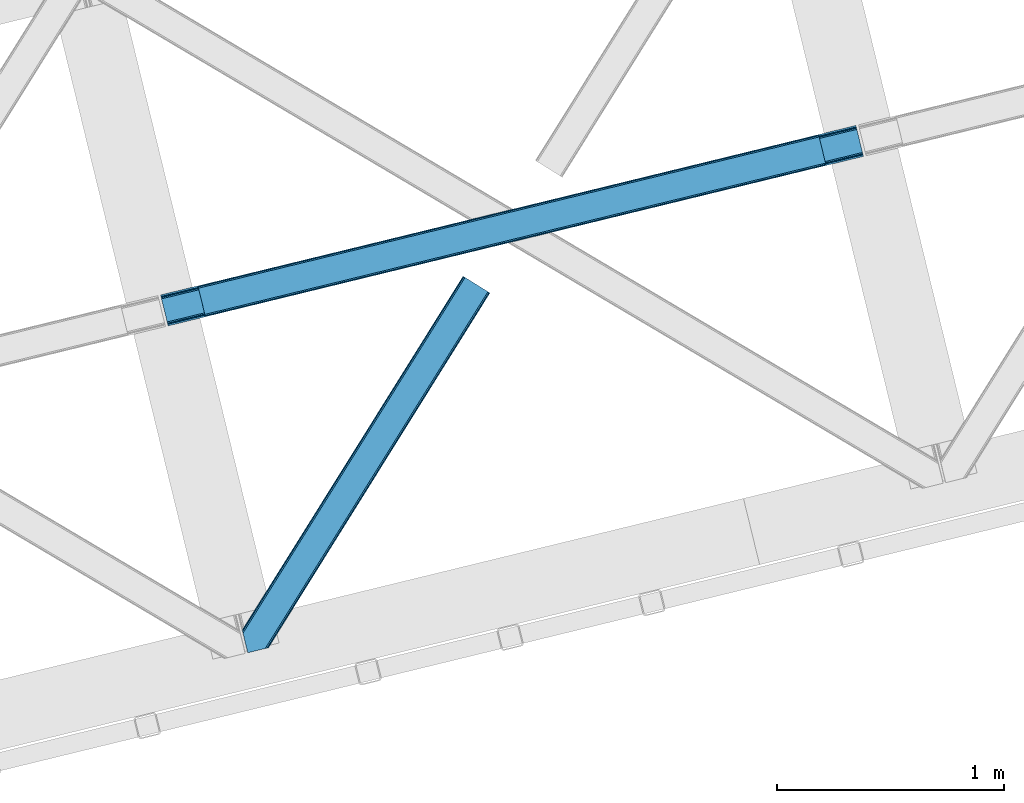
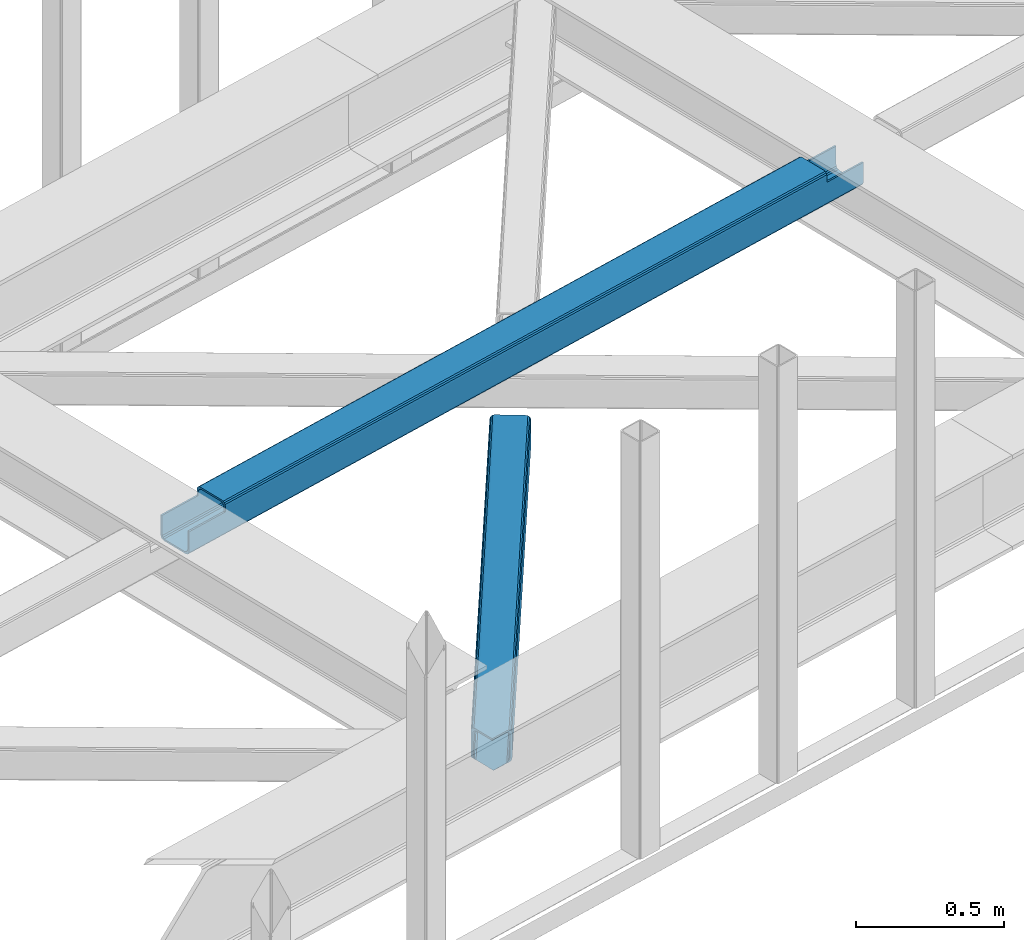
# One storey, part 42 of 67: 1 beam, 1 member.
"""IFC4 building model written with IfcOpenShell, lengths in millimetres."""

from ifc_helpers import new_model, entity, si_unit, converted_unit, derived_unit, direction, frame, origin, place, context, subcontext, project, spatial, triangles, polygons, material, type_object, element, save


model = new_model("IFC4")

# Units and contexts
model_context = context("Model", 3, precision=0.01, world=origin(), true_north=direction((6.12303176911189e-17, 1.0)))
plan_context = context("Plan", 3, precision=0.01, world=origin(), true_north=direction((6.12303176911189e-17, 1.0)))
body_context = subcontext(model_context, "Body", "Model", "MODEL_VIEW")
ifc_project = project(units=[si_unit("LENGTHUNIT", "METRE", prefix="MILLI"), si_unit("AREAUNIT", "SQUARE_METRE"), si_unit("VOLUMEUNIT", "CUBIC_METRE"), converted_unit("PLANEANGLEUNIT", "DEGREE", entity("IfcRatioMeasure", 0.0174532925199433), si_unit("PLANEANGLEUNIT", "RADIAN"), dimensions=[0, 0, 0, 0, 0, 0, 0]), si_unit("MASSUNIT", "GRAM", prefix="KILO"), derived_unit("MASSDENSITYUNIT", [(si_unit("MASSUNIT", "GRAM", prefix="KILO"), 1), (si_unit("LENGTHUNIT", "METRE"), -3)]), derived_unit("MOMENTOFINERTIAUNIT", [(si_unit("LENGTHUNIT", "METRE"), 4)]), si_unit("TIMEUNIT", "SECOND"), si_unit("FREQUENCYUNIT", "HERTZ"), si_unit("THERMODYNAMICTEMPERATUREUNIT", "DEGREE_CELSIUS"), derived_unit("THERMALTRANSMITTANCEUNIT", [(si_unit("MASSUNIT", "GRAM", prefix="KILO"), 1), (si_unit("THERMODYNAMICTEMPERATUREUNIT", "KELVIN"), -1), (si_unit("TIMEUNIT", "SECOND"), -3)]), derived_unit("VOLUMETRICFLOWRATEUNIT", [(si_unit("LENGTHUNIT", "METRE"), 3), (si_unit("TIMEUNIT", "SECOND"), -1)]), derived_unit("MASSFLOWRATEUNIT", [(si_unit("MASSUNIT", "GRAM", prefix="KILO"), 1), (si_unit("TIMEUNIT", "SECOND"), -1)]), derived_unit("ROTATIONALFREQUENCYUNIT", [(si_unit("TIMEUNIT", "SECOND"), -1)]), si_unit("ELECTRICCURRENTUNIT", "AMPERE"), si_unit("ELECTRICVOLTAGEUNIT", "VOLT"), si_unit("POWERUNIT", "WATT"), si_unit("FORCEUNIT", "NEWTON", prefix="KILO"), si_unit("ILLUMINANCEUNIT", "LUX"), si_unit("LUMINOUSFLUXUNIT", "LUMEN"), si_unit("LUMINOUSINTENSITYUNIT", "CANDELA"), derived_unit("USERDEFINED", [(si_unit("MASSUNIT", "GRAM", prefix="KILO"), -1), (si_unit("LENGTHUNIT", "METRE"), -2), (si_unit("TIMEUNIT", "SECOND"), 3), (si_unit("LUMINOUSFLUXUNIT", "LUMEN"), 1)]), derived_unit("LINEARVELOCITYUNIT", [(si_unit("LENGTHUNIT", "METRE"), 1), (si_unit("TIMEUNIT", "SECOND"), -1)]), si_unit("PRESSUREUNIT", "PASCAL"), derived_unit("USERDEFINED", [(si_unit("LENGTHUNIT", "METRE"), -2), (si_unit("MASSUNIT", "GRAM", prefix="KILO"), 1), (si_unit("TIMEUNIT", "SECOND"), -2)]), derived_unit("LINEARFORCEUNIT", [(si_unit("MASSUNIT", "GRAM", prefix="KILO"), 1), (si_unit("LENGTHUNIT", "METRE"), 1), (si_unit("TIMEUNIT", "SECOND"), -2), (si_unit("LENGTHUNIT", "METRE"), -1)]), derived_unit("PLANARFORCEUNIT", [(si_unit("MASSUNIT", "GRAM", prefix="KILO"), 1), (si_unit("LENGTHUNIT", "METRE"), 1), (si_unit("TIMEUNIT", "SECOND"), -2), (si_unit("LENGTHUNIT", "METRE"), -2)])], contexts=[model_context, plan_context])

# Site, building, storey
site_placement = place(None, origin())
site = spatial("IfcSite", under=ifc_project, at=site_placement, CompositionType="ELEMENT")
building_placement = place(site_placement, origin())
building = spatial("IfcBuilding", under=site, at=building_placement, CompositionType="ELEMENT")
storey_placement = place(building_placement, frame((0.0, 0.0, 19800.0)))
storey = spatial("IfcBuildingStorey", under=building, at=storey_placement, CompositionType="ELEMENT", Elevation=19800.0)

# Beam
ifc_material = material(Name="Metal painted (White)")
beam_type = type_object("IfcBeamType", PredefinedType="BEAM")
beam_placement = place(storey_placement, frame((-23668.0844907554, 13370.596470342, 3967.02022389142)))
element("IfcBeam", 1, at=beam_placement, inside=storey, type_object=beam_type, material=ifc_material, ObjectType="Steel Beam", PredefinedType="BEAM", context=body_context, shape_type="Tessellation", body=[
    polygons([(31.1823923917571, 8.09507685196108, 17.8030399336114), (31.4978703677187, 6.80086440699217, 24.4999999999988), (3089.94374939707, 752.329405140572, 24.4999999999988), (3089.62827142112, 753.623617585543, 17.8030399336114), (30.2839871259035, 11.7806820741864, 12.1256313292298), (3088.72986615527, 757.309222807771, 12.1256313292298), (28.9394286278234, 17.2965800886753, 8.33210818105214), (3087.38530765718, 762.82512082226, 8.33210818105214), (27.3534137403861, 23.8030254244683, 7.00000000000274), (3085.79929276975, 769.331566158049, 7.00000000000274), (4.21622439082827, 118.720708051134, 8.33210818105214), (5.80223927826556, 112.214262715343, 7.00000000000274), (3064.24811830762, 857.742803448927, 7.00000000000274), (3062.66210342019, 864.249248784716, 8.33210818105214), (2.87166589274824, 124.236606065622, 12.1256313292342), (3061.31754492211, 869.765146799203, 12.1256313292342), (1.9732606268946, 127.922211287848, 17.8030399336114), (3060.41913965625, 873.450752021432, 17.8030399336114), (1.65778265093735, 129.216423732819, 24.4999999999988), (3060.10366168028, 874.744964466397, 24.4999999999988), (33.1556530186517, 2.16573425859679e-12, 17.5000000000004), (33.155653018656, 2.16573425859679e-12, 99.499999999999), (31.4978703677273, 6.80086440699434, 99.499999999999), (1.65778265094168, 129.216423732819, 99.499999999999), (1.29944055515807e-11, 136.017288139811, 99.499999999999), (8.66293703438714e-12, 136.017288139811, 17.5000000000004), (0.315477975970248, 134.72307569484, 10.803039933613), (1.21388324181955, 131.037470472615, 5.12563132923143), (2.55844173990391, 125.521572458126, 1.33210818105373), (4.14445662733688, 119.015127122335, 0.0), (29.0111963913235, 17.0021610174783, 0.0), (30.5972112787608, 10.4957156816875, 1.33210818105373), (31.9417697768408, 4.97981766719851, 5.12563132923576), (32.8401750426944, 1.29421244497107, 10.803039933613), (3058.44587902935, 881.545828873387, 17.5000000000004), (3058.44587902935, 881.545828873387, 99.499999999999), (3060.10366168027, 874.744964466395, 99.499999999999), (3089.94374939706, 752.32940514057, 99.499999999999), (3091.60153204799, 745.52854073358, 99.499999999999), (3091.60153204799, 745.52854073358, 17.5000000000004), (3091.28605407204, 746.822753178549, 10.803039933613), (3090.38764880618, 750.508358400772, 5.12563132923576), (3089.0430903081, 756.024256415263, 1.33210818105373), (3087.45707542067, 762.530701751056, 0.0), (3062.59033565668, 864.543667855911, 0.0), (3061.00432076925, 871.050113191702, 1.33210818105373), (3059.65976227116, 876.566011206191, 5.12563132923143), (3058.76135700531, 880.251616428418, 10.803039933613), (2925.75994180944, 712.307865540887, 115.5000123926), (2925.8163098943, 712.321604759503, 100.117303289864), (2926.72300362931, 712.542621518197, 99.499999999999), (194.718606580809, 46.58768115868, 99.5063429816656), (195.631369831921, 46.8101414945073, 100.117301735448), (195.690168193635, 46.8244741223611, 115.5), (2928.38078628024, 705.741757111205, 99.499999999999), (2927.47422618799, 705.520772937698, 100.117303484932), (2927.41464342032, 705.506249905356, 122.500007895425), (197.345360928056, 40.0229783796067, 122.500002534479), (197.338587096745, 40.0213271441479, 100.500009163303), (196.748205195729, 39.8773799905087, 99.5697919021647), (2896.88292546721, 834.958147714716, 99.5063429816656), (2895.97381660775, 834.736577552001, 100.117299778624), (2895.91744852288, 834.722838333383, 115.50000888136), (165.85008047685, 169.240033448183, 115.5), (165.840462203347, 169.237688832044, 100.50000941238), (165.250325295037, 169.093836777333, 99.5761204674868), (2894.8533268523, 841.668448882887, 99.5697919021647), (163.220745767778, 175.804071762186, 99.499999999999), (164.133244938523, 176.026503182401, 100.117301984524), (164.189439987641, 176.04020120897, 122.500002796667), (2894.25631754638, 841.522886341466, 122.500003994045), (2894.2664208352, 841.525349756033, 100.500018741102), (2894.56843170076, 840.227853719303, 129.196959150505), (2895.46176722634, 836.541012377608, 134.874360354937), (2896.80305823041, 831.024317672804, 138.667878733795), (2898.38810531641, 824.517636364728, 139.999985502214), (2923.25885436335, 722.505647815416, 139.999991354283), (2924.84634848093, 715.999563150013, 138.667885332354), (2926.19460804137, 710.484567539782, 134.874367586349), (2927.09837274858, 706.800269072832, 129.196966804773), (2925.44675217774, 713.602635936904, 122.196975799125), (2924.54298747052, 717.286934403861, 127.874376580702), (2923.19472791009, 722.801930014085, 131.667894326702), (2921.6072337925, 729.30801467949, 133.000000348631), (2900.0525846185, 817.718404755559, 132.999995276841), (2898.46753753249, 824.225086063634, 131.667888508414), (2897.12624652842, 829.741780768443, 127.874370129564), (2896.23291100283, 833.428622110133, 122.196968925133), (164.878528418711, 169.003207355196, 99.499999999999), (193.13172645374, 57.3201898040421, 131.667891818946), (191.545711566303, 63.8266351398372, 133.0), (194.476284951825, 51.8042917895531, 127.874368670764), (195.374690217678, 48.11868656733, 122.196960066391), (169.994537104182, 152.237872430714, 133.0), (166.165558452811, 167.945821003219, 122.196960066391), (167.063963718665, 164.260215780994, 127.874368670764), (168.408522216745, 158.744317766505, 131.667891818946), (197.031411944082, 41.3175635421181, 129.196961104604), (196.136488323074, 45.0040174739024, 134.874366301861), (194.794244157323, 50.5204796458751, 138.667887185257), (193.209023953591, 57.0271186992037, 139.999994588639), (168.341882306945, 159.039986838394, 139.999994981919), (166.755021471193, 165.546225960036, 138.667887628704), (165.408105180739, 171.061549222932, 134.874366787843), (164.506189230969, 174.746298656828, 129.196961619)], [[[1, 2, 3, 4]], [[5, 1, 4, 6]], [[7, 5, 6, 8]], [[9, 7, 8, 10]], [[11, 12, 13, 14]], [[15, 11, 14, 16]], [[17, 15, 16, 18]], [[19, 17, 18, 20]], [[12, 9, 10, 13]], [[21, 22, 23, 2, 1, 5, 7, 9, 12, 11, 15, 17, 19, 24, 25, 26, 27, 28, 29, 30, 31, 32, 33, 34]], [[35, 36, 37, 20, 18, 16, 14, 13, 10, 8, 6, 4, 3, 38, 39, 40, 41, 42, 43, 44, 45, 46, 47, 48]], [[49, 50, 51, 38, 3, 2, 23, 52, 53, 54]], [[55, 39, 38, 51]], [[39, 55, 56, 57, 58, 59, 60, 22, 21, 40]], [[32, 31, 44, 43]], [[33, 32, 43, 42]], [[34, 33, 42, 41]], [[21, 34, 41, 40]], [[31, 30, 45, 44]], [[27, 26, 35, 48]], [[28, 27, 48, 47]], [[29, 28, 47, 46]], [[30, 29, 46, 45]], [[20, 37, 61, 62, 63, 64, 65, 66, 24, 19]], [[67, 36, 35, 26, 25, 68, 69, 70, 71, 72]], [[36, 67, 61, 37]], [[72, 71, 73, 74, 75, 76, 77, 78, 79, 80, 57, 56, 50, 49, 81, 82, 83, 84, 85, 86, 87, 88, 63, 62]], [[60, 52, 23, 22]], [[25, 24, 89, 68]], [[90, 91, 84, 83]], [[92, 90, 83, 82]], [[93, 92, 82, 81]], [[54, 93, 81, 49]], [[94, 85, 84, 91]], [[95, 64, 63, 88]], [[96, 95, 88, 87]], [[97, 96, 87, 86]], [[94, 97, 86, 85]], [[65, 64, 95, 96, 97, 94, 91, 90, 92, 93, 54, 53, 59, 58, 98, 99, 100, 101, 102, 103, 104, 105, 70, 69]], [[98, 58, 57, 80]], [[99, 98, 80, 79]], [[100, 99, 79, 78]], [[101, 100, 78, 77]], [[77, 76, 102, 101]], [[103, 102, 76, 75]], [[104, 103, 75, 74]], [[105, 104, 74, 73]], [[70, 105, 73, 71]]], closed=False),
])

# Member
member_type = type_object("IfcMemberType", PredefinedType="BRACE")
member_placement = place(storey_placement, frame((-23308.988873291, 11932.6995483398, 3822.99993896484)))
element("IfcMember", 2, at=member_placement, inside=storey, type_object=member_type, ObjectType="Steel Horizontal Brace", PredefinedType="BRACE", context=body_context, shape_type="Tessellation", body=[
    triangles([(986.153759765624, 1647.42967529297, 0.0), (1075.22274169922, 1591.82725524902, 0.0), (119.790362548825, 259.603921508789, 0.0), (154.551031494138, 117.003323364257, 0.0), (115.904553222656, 275.544808959961, 4.52065429687718), (117.571893310545, 268.698715209961, 1.33247680664135), (158.436840820312, 101.062435913085, 4.52065429687718), (156.767175292967, 107.908529663086, 1.33247680664135), (114.825549316403, 275.742471313477, 5.52059326172093), (115.132507324219, 275.92385559082, 5.35316162109302), (158.132208251951, 99.1218566894531, 5.27642211914281), (115.441790771481, 276.107565307617, 5.18107910156323), (158.234527587891, 99.7776306152336, 5.02062377929906), (158.190344238279, 99.4822998046875, 5.13457031250073), (115.544110107421, 276.168026733398, 5.12526855468968), (115.68596191406, 275.921530151367, 4.88574829101708), (158.336846923827, 100.433404541016, 4.76482543945531), (158.032214355466, 98.4928253173821, 5.52059326172093), (1085.71977539062, 1585.27416687012, 5.12526855468968), (1080.9037902832, 1588.28096008301, 1.33247680664135), (1088.93818359375, 1583.26498718262, 10.8039916992202), (114.21163330078, 21.8533172607422, 10.8039916992202), (109.467736816405, 20.6964111328125, 5.52059326172093), (1090.06834716797, 1582.55921630859, 17.5012573242202), (116.062683105469, 22.3044525146488, 17.5012573242202), (6.75307617187354, 102.619317626953, 5.52059326172093), (31.3655273437471, 1.65803833007885, 5.52059326172093), (1090.06834716797, 1582.55921630859, 122.499499511719), (116.062683105469, 22.3044525146488, 122.499499511719), (1088.93818359375, 1583.26498718262, 129.196765136719), (114.21163330078, 21.8533172607422, 129.196765136719), (1085.71977539062, 1585.27416687012, 134.87548828125), (108.937536621092, 20.5673492431633, 134.87548828125), (1080.9037902832, 1588.28096008301, 138.668280029298), (101.042669677732, 18.6430480957024, 138.668280029298), (1075.22274169922, 1591.82725524902, 140.00075683594), (91.7292846679666, 16.3722564697273, 140.00075683594), (980.472711181639, 1650.97597045899, 1.33247680664135), (975.656726074216, 1653.98276367187, 5.12526855468968), (1.69059448242115, 100.410150146485, 10.9621215820334), (972.438317871092, 1655.99078063965, 10.8039916992202), (971.310479736327, 1656.69655151367, 17.5012573242202), (0.239520263668965, 99.7776306152336, 12.5201660156272), (0.0, 100.760128784179, 17.5012573242202), (5.79266967773219, 76.992974853516, 140.00075683594), (986.153759765624, 1647.42967529297, 140.00075683594), (24.5612915039055, 0.0, 140.00075683594), (971.310479736327, 1656.69655151367, 122.499499511719), (0.0, 100.760128784179, 122.499499511719), (980.472711181639, 1650.97597045899, 138.668280029298), (3.57652587890334, 86.0889312744148, 138.668280029298), (975.656726074216, 1653.98276367187, 134.87548828125), (1.69757080078125, 93.7989257812496, 134.87548828125), (972.438317871092, 1655.99078063965, 129.196765136719), (0.44183349609375, 98.9509368896488, 129.196765136719), (29.9260803222642, 1.30689697265552, 6.99957275390625), (12.1969299316406, 74.0326904296871, 6.99957275390625), (8.99479980468459, 81.5485107421882, 8.3320495605476), (3.88813476562427, 84.8122650146488, 12.5201660156272), (1069.28356933594, 1595.53400573731, 6.99957275390625), (81.9973205566384, 14.0003082275398, 6.99957275390625), (992.092932128904, 1643.72292480469, 6.99957275390625), (981.593572998045, 1650.27485046387, 12.1248413085959), (978.379815673827, 1652.28519287109, 17.8035644531265), (2.75797119140407, 89.4445404052731, 17.8035644531265), (986.409558105468, 1647.26805725098, 8.3320495605476), (977.245001220701, 1652.98863830566, 24.5008300781265), (2.3184631347649, 91.2537322998051, 24.5008300781265), (977.245001220701, 1652.98863830566, 115.499926757813), (2.3184631347649, 91.2537322998051, 115.499926757813), (4.01370849609157, 84.2925292968757, 127.873590087893), (2.75797119140407, 89.4445404052731, 122.197192382813), (5.89498901367188, 76.5813720703118, 131.668707275392), (8.11113281249709, 67.4865783691403, 133.001184082033), (24.5612915039055, 0.0, 133.001184082033), (978.379815673827, 1652.28519287109, 122.197192382813), (981.593572998045, 1650.27485046387, 127.873590087893), (986.409558105468, 1647.26805725098, 131.668707275392), (992.092932128904, 1643.72292480469, 133.001184082033), (1069.28356933594, 1595.53400573731, 133.001184082033), (81.9973205566384, 14.0003082275398, 133.001184082033), (1079.78060302734, 1588.9809173584, 12.1248413085959), (1082.99901123047, 1586.9717376709, 17.8035644531265), (1084.12917480469, 1586.26596679687, 24.5008300781265), (1074.96461791992, 1591.98654785156, 8.3320495605476), (1079.78060302734, 1588.9809173584, 127.873590087893), (1084.12917480469, 1586.26596679687, 115.499926757813), (1082.99901123047, 1586.9717376709, 122.197192382813), (1074.96461791992, 1591.98654785156, 131.668707275392), (91.3107055664041, 16.2699371337894, 131.668707275392), (99.2032470703125, 18.1942382812504, 127.873590087893), (104.479669189452, 19.4802062988274, 122.197192382813), (106.330718994141, 19.931341552734, 115.499926757813), (91.3107055664041, 16.2699371337894, 8.3320495605476), (104.479669189452, 19.4802062988274, 17.8035644531265), (99.2032470703125, 18.1942382812504, 12.1248413085959), (106.330718994141, 19.931341552734, 24.5008300781265)], [[1, 2, 3], [4, 3, 2], [5, 3, 4], [3, 5, 6], [4, 7, 5], [7, 4, 8], [9, 10, 11], [10, 12, 13], [13, 14, 10], [12, 15, 16], [16, 17, 12], [16, 5, 7], [7, 17, 16], [17, 13, 12], [14, 11, 10], [11, 18, 9], [19, 14, 13], [13, 20, 19], [13, 17, 20], [17, 7, 20], [7, 8, 20], [21, 22, 18], [18, 19, 21], [14, 19, 11], [18, 11, 19], [22, 23, 18], [21, 24, 25], [25, 22, 21], [2, 20, 4], [8, 4, 20], [23, 26, 18], [23, 27, 26], [9, 18, 26], [24, 28, 29], [29, 25, 24], [28, 30, 29], [31, 29, 30], [30, 32, 31], [33, 31, 32], [32, 34, 33], [35, 33, 34], [34, 36, 35], [37, 35, 36], [38, 6, 5], [5, 39, 38], [5, 15, 39], [40, 41, 9], [41, 39, 15], [42, 41, 40], [40, 43, 42], [43, 44, 42], [9, 26, 40], [38, 1, 6], [3, 6, 1], [36, 45, 37], [36, 46, 45], [45, 47, 37], [48, 42, 44], [44, 49, 48], [46, 50, 51], [51, 45, 46], [50, 52, 53], [53, 51, 50], [52, 54, 55], [55, 53, 52], [54, 48, 49], [49, 55, 54], [27, 56, 57], [26, 57, 58], [57, 26, 27], [59, 40, 26], [26, 58, 59], [43, 40, 59], [60, 57, 61], [60, 62, 57], [57, 56, 61], [63, 64, 65], [65, 59, 63], [66, 63, 59], [62, 66, 58], [58, 57, 62], [59, 58, 66], [64, 67, 68], [68, 65, 64], [67, 69, 70], [70, 68, 67], [71, 53, 72], [73, 74, 45], [74, 47, 45], [74, 75, 47], [51, 73, 45], [71, 51, 53], [71, 73, 51], [49, 68, 70], [55, 72, 53], [70, 72, 49], [72, 55, 49], [44, 68, 49], [43, 59, 65], [65, 68, 44], [44, 43, 65], [69, 76, 70], [72, 70, 76], [76, 77, 72], [71, 72, 77], [77, 78, 71], [73, 71, 78], [78, 79, 73], [74, 73, 79], [80, 74, 79], [74, 80, 81], [75, 74, 81], [21, 82, 83], [84, 28, 24], [21, 83, 24], [21, 19, 82], [83, 84, 24], [82, 19, 20], [60, 2, 1], [2, 85, 20], [85, 2, 60], [85, 82, 20], [30, 86, 32], [87, 28, 84], [28, 88, 30], [88, 28, 87], [30, 88, 86], [36, 80, 46], [34, 32, 86], [86, 89, 34], [89, 80, 36], [36, 34, 89], [63, 38, 39], [1, 62, 60], [1, 66, 62], [66, 1, 38], [63, 66, 38], [67, 42, 48], [41, 64, 63], [39, 41, 63], [64, 41, 42], [67, 64, 42], [50, 77, 52], [46, 80, 79], [79, 78, 46], [78, 77, 50], [50, 46, 78], [54, 52, 77], [48, 69, 67], [76, 48, 54], [48, 76, 69], [76, 54, 77], [35, 37, 90], [47, 81, 37], [81, 47, 75], [81, 90, 37], [91, 35, 90], [91, 33, 35], [33, 92, 31], [92, 33, 91], [29, 92, 93], [92, 29, 31], [61, 23, 94], [95, 96, 23], [96, 94, 23], [61, 27, 23], [27, 61, 56], [97, 95, 25], [22, 25, 95], [29, 97, 25], [97, 29, 93], [95, 23, 22], [80, 89, 90], [90, 81, 80], [89, 86, 91], [91, 90, 89], [86, 88, 92], [92, 91, 86], [88, 87, 93], [93, 92, 88], [87, 84, 93], [97, 93, 84], [84, 83, 97], [95, 97, 83], [83, 82, 95], [96, 95, 82], [82, 85, 96], [94, 96, 85], [85, 60, 94], [61, 94, 60]]),
])

save(model, "model.ifc")
